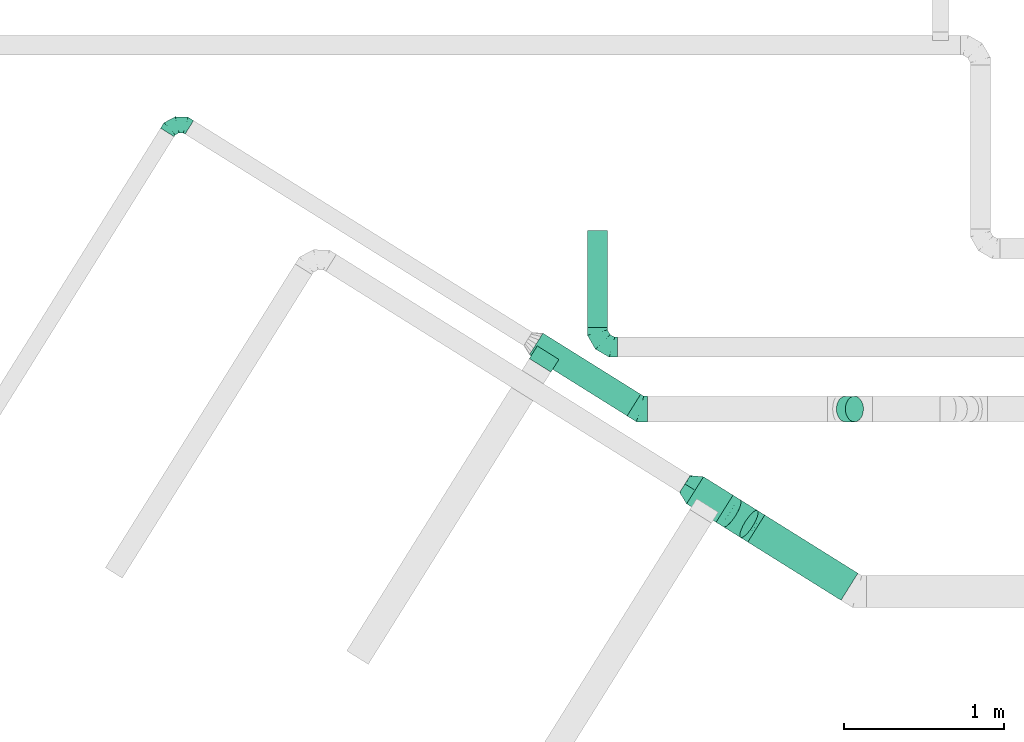
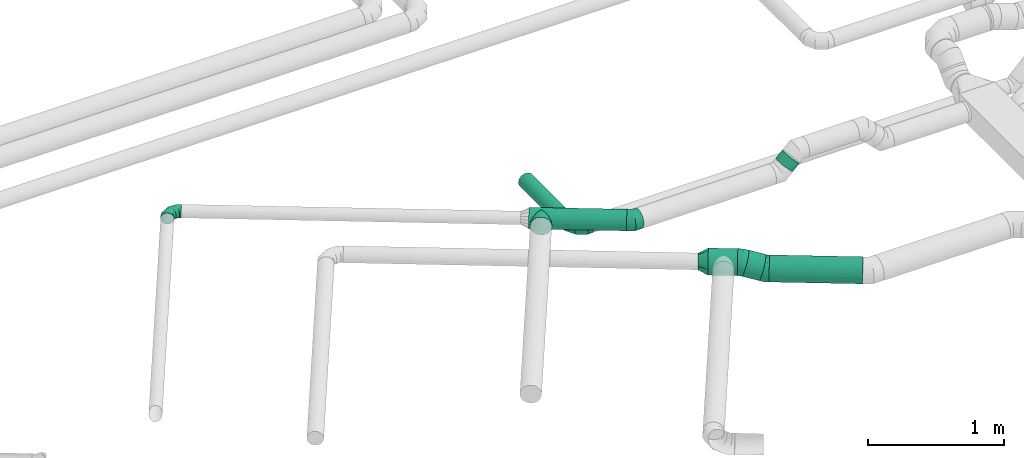
# One storey, part 9 of 60: 7 flow fittings, 6 flow segments.
"""IFC2X3 building model written with IfcOpenShell, lengths in millimetres."""

from ifc_helpers import new_model, entity, si_unit, converted_unit, derived_unit, direction, frame, origin, origin_2d_with_axis, place, context, subcontext, project, spatial, circle, extrude, faceted_brep, source, transform, mapped, material, type_object, type_shapes, element, save


model = new_model("IFC2X3")

# Units and contexts
model_context = context("Model", 3, precision=0.01, world=origin(), true_north=direction((6.12303176911189e-17, 1.0)))
body_context = subcontext(model_context, "Body", "Model", "MODEL_VIEW")
ifc_project = project(units=[si_unit("LENGTHUNIT", "METRE", prefix="MILLI"), si_unit("AREAUNIT", "SQUARE_METRE"), si_unit("VOLUMEUNIT", "CUBIC_METRE"), converted_unit("PLANEANGLEUNIT", "DEGREE", entity("IfcRatioMeasure", 0.0174532925199433), si_unit("PLANEANGLEUNIT", "RADIAN"), dimensions=[0, 0, 0, 0, 0, 0, 0]), si_unit("MASSUNIT", "GRAM", prefix="KILO"), derived_unit("MASSDENSITYUNIT", [(si_unit("MASSUNIT", "GRAM", prefix="KILO"), 1), (si_unit("LENGTHUNIT", "METRE"), -3)]), derived_unit("MOMENTOFINERTIAUNIT", [(si_unit("LENGTHUNIT", "METRE"), 4)]), si_unit("TIMEUNIT", "SECOND"), si_unit("FREQUENCYUNIT", "HERTZ"), si_unit("THERMODYNAMICTEMPERATUREUNIT", "DEGREE_CELSIUS"), derived_unit("THERMALTRANSMITTANCEUNIT", [(si_unit("MASSUNIT", "GRAM", prefix="KILO"), 1), (si_unit("THERMODYNAMICTEMPERATUREUNIT", "KELVIN"), -1), (si_unit("TIMEUNIT", "SECOND"), -3)]), derived_unit("VOLUMETRICFLOWRATEUNIT", [(si_unit("LENGTHUNIT", "METRE"), 3), (si_unit("TIMEUNIT", "SECOND"), -1)]), derived_unit("MASSFLOWRATEUNIT", [(si_unit("MASSUNIT", "GRAM", prefix="KILO"), 1), (si_unit("TIMEUNIT", "SECOND"), -1)]), derived_unit("ROTATIONALFREQUENCYUNIT", [(si_unit("TIMEUNIT", "SECOND"), -1)]), si_unit("ELECTRICCURRENTUNIT", "AMPERE"), si_unit("ELECTRICVOLTAGEUNIT", "VOLT"), si_unit("POWERUNIT", "WATT"), si_unit("FORCEUNIT", "NEWTON", prefix="KILO"), si_unit("ILLUMINANCEUNIT", "LUX"), si_unit("LUMINOUSFLUXUNIT", "LUMEN"), si_unit("LUMINOUSINTENSITYUNIT", "CANDELA"), derived_unit("USERDEFINED", [(si_unit("MASSUNIT", "GRAM", prefix="KILO"), -1), (si_unit("LENGTHUNIT", "METRE"), -2), (si_unit("TIMEUNIT", "SECOND"), 3), (si_unit("LUMINOUSFLUXUNIT", "LUMEN"), 1)]), derived_unit("LINEARVELOCITYUNIT", [(si_unit("LENGTHUNIT", "METRE"), 1), (si_unit("TIMEUNIT", "SECOND"), -1)]), si_unit("PRESSUREUNIT", "PASCAL"), derived_unit("USERDEFINED", [(si_unit("LENGTHUNIT", "METRE"), -2), (si_unit("MASSUNIT", "GRAM", prefix="KILO"), 1), (si_unit("TIMEUNIT", "SECOND"), -2)]), derived_unit("LINEARFORCEUNIT", [(si_unit("MASSUNIT", "GRAM", prefix="KILO"), 1), (si_unit("LENGTHUNIT", "METRE"), 1), (si_unit("TIMEUNIT", "SECOND"), -2), (si_unit("LENGTHUNIT", "METRE"), -1)]), derived_unit("PLANARFORCEUNIT", [(si_unit("MASSUNIT", "GRAM", prefix="KILO"), 1), (si_unit("LENGTHUNIT", "METRE"), 1), (si_unit("TIMEUNIT", "SECOND"), -2), (si_unit("LENGTHUNIT", "METRE"), -2)])], contexts=[model_context])

# Site, building, storey
site_placement = place(None, origin())
site = spatial("IfcSite", under=ifc_project, at=site_placement, CompositionType="ELEMENT")
building_placement = place(site_placement, origin())
building = spatial("IfcBuilding", under=site, at=building_placement, CompositionType="ELEMENT")
storey_placement = place(building_placement, frame((0.0, 0.0, 19800.0)))
storey = spatial("IfcBuildingStorey", under=building, at=storey_placement, CompositionType="ELEMENT", Elevation=19800.0)

# Flow segments
duct_segment_type = type_object("IfcDuctSegmentType", PredefinedType="NOTDEFINED")
flow_segment_1_placement = place(storey_placement, frame((13336.18, 9832.66, 3135.9)))
element("IfcFlowSegment", 1, at=flow_segment_1_placement, inside=storey, type_object=duct_segment_type, context=body_context, shape_type="SweptSolid", body=[
    extrude(circle(Radius=62.5, at=origin_2d_with_axis()), frame((64.1, 0.0, 64.1), z_axis=(0.0, 1.0, 0.0), x_axis=(1.0, 0.0, 0.0)), (0.0, 0.0, 1.0), 607.500000000031),
])
flow_segment_2_placement = place(storey_placement, frame((12972.44, 9275.3, 3343.4)))
element("IfcFlowSegment", 2, at=flow_segment_2_placement, inside=storey, type_object=duct_segment_type, context=body_context, shape_type="SweptSolid", body=[
    extrude(circle(Radius=80.0, at=origin_2d_with_axis()), frame((43.99, 452.23, 81.6), z_axis=(0.848048096156417, -0.52991926423322, 0.0), x_axis=(0.52991926423322, 0.848048096156417, 0.0)), (0.0, 0.0, 1.0), 722.361212402773),
])
flow_segment_3_placement = place(storey_placement, frame((14341.56, 8119.93, 3088.4)))
element("IfcFlowSegment", 3, at=flow_segment_3_placement, inside=storey, type_object=duct_segment_type, context=body_context, shape_type="SweptSolid", body=[
    extrude(circle(Radius=100.0, at=origin_2d_with_axis()), frame((54.59, 451.16, 101.6), z_axis=(0.848048096156417, -0.529919264233219, 0.0), x_axis=(0.529919264233219, 0.848048096156417, 0.0)), (0.0, 0.0, 1.0), 688.339841577361),
])
flow_segment_4_placement = place(storey_placement, frame((13957.85, 8609.03, 3138.99)))
element("IfcFlowSegment", 4, at=flow_segment_4_placement, inside=storey, type_object=duct_segment_type, context=body_context, shape_type="SweptSolid", body=[
    extrude(circle(Radius=100.0, at=origin_2d_with_axis()), frame((239.32, 86.4, 101.6), z_axis=(-0.848052743777578, 0.529911826412019, 0.0), x_axis=(0.529911826412019, 0.848052743777578, 0.0)), (0.0, 0.0, 1.0), 217.830106904879),
])
flow_segment_5_placement = place(storey_placement, frame((14184.22, 8512.64, 3099.68)))
element("IfcFlowSegment", 5, at=flow_segment_5_placement, inside=storey, type_object=duct_segment_type, context=body_context, shape_type="SweptSolid", body=[
    extrude(circle(Radius=100.0, at=origin_2d_with_axis()), frame((165.87, 87.23, 97.84), z_axis=(-0.816176385066245, 0.510025682151549, 0.271532524766454), x_axis=(-0.529935758696196, -0.848037789048983, 0.0)), (0.0, 0.0, 1.0), 130.942735235009),
])
flow_segment_6_placement = place(storey_placement, frame((14896.63, 9238.83, 3413.7)))
element("IfcFlowSegment", 6, at=flow_segment_6_placement, inside=storey, type_object=duct_segment_type, context=body_context, shape_type="SweptSolid", body=[
    extrude(circle(Radius=80.0, at=origin_2d_with_axis()), frame((58.16, 81.6, 58.16), z_axis=(0.707106781186548, 0.0, 0.707106781186548), x_axis=(0.0, -1.0, 0.0)), (0.0, 0.0, 1.0), 79.5836943965932),
])

# Flow fittings
ifc_material = material()
duct_fitting_type_1 = type_object("IfcDuctFittingType", PredefinedType="NOTDEFINED", material=ifc_material)
shared_shape_1 = source(origin(), body_context, "Body", "Brep", [
    faceted_brep([(-100.0, 0.0, -50.0), (-100.0, -12.94, -48.3), (-100.0, -25.0, -43.3), (-100.0, -35.36, -35.36), (-100.0, -43.3, -25.0), (-100.0, -48.3, -12.94), (-100.0, -50.0, 0.0), (-100.0, -48.3, 12.94), (-100.0, -43.3, 25.0), (-100.0, -35.36, 35.36), (-100.0, -25.0, 43.3), (-100.0, -12.94, 48.3), (-100.0, 0.0, 50.0), (-100.0, 12.94, 48.3), (-100.0, 25.0, 43.3), (-100.0, 35.36, 35.36), (-100.0, 43.3, 25.0), (-100.0, 48.3, 12.94), (-100.0, 50.0, 0.0), (-100.0, 48.3, -12.94), (-100.0, 43.3, -25.0), (-100.0, 35.36, -35.36), (-100.0, 25.0, -43.3), (-100.0, 12.94, -48.3), (-76.67, 12.94, 48.3), (-79.9, 25.0, 43.3), (-73.21, 0.0, 50.0), (-82.68, 35.36, 35.36), (-86.15, 48.3, 12.94), (-86.6, 50.0, 0.0), (-84.81, 43.3, 25.0), (-84.81, 43.3, -25.0), (-82.68, 35.36, -35.36), (-86.15, 48.3, -12.94), (-76.67, 12.94, -48.3), (-73.21, 0.0, -50.0), (-79.9, 25.0, -43.3), (-69.74, -12.94, -48.3), (-66.51, -25.0, -43.3), (-63.73, -35.36, -35.36), (-61.6, -43.3, -25.0), (-60.26, -48.3, -12.94), (-59.81, -50.0, 0.0), (-60.26, -48.3, 12.94), (-61.6, -43.3, 25.0), (-63.73, -35.36, 35.36), (-66.51, -25.0, 43.3), (-69.74, -12.94, 48.3), (-36.27, 36.27, 48.3), (-45.1, 45.1, 43.3), (-26.79, 26.79, 50.0), (-52.68, 52.68, 35.36), (-58.49, 58.49, 25.0), (-62.15, 62.15, 12.94), (-63.4, 63.4, 0.0), (-62.15, 62.15, -12.94), (-58.49, 58.49, -25.0), (-52.68, 52.68, -35.36), (-36.27, 36.27, -48.3), (-26.79, 26.79, -50.0), (-45.1, 45.1, -43.3), (-17.32, 17.32, -48.3), (-8.49, 8.49, -43.3), (-0.91, 0.91, -35.36), (4.9, -4.9, -25.0), (8.56, -8.56, -12.94), (9.81, -9.81, 0.0), (8.56, -8.56, 12.94), (4.9, -4.9, 25.0), (-0.91, 0.91, 35.36), (-8.49, 8.49, 43.3), (-17.32, 17.32, 48.3), (-12.94, 76.67, 48.3), (-25.0, 79.9, 43.3), (0.0, 73.21, 50.0), (-35.36, 82.68, 35.36), (-43.3, 84.81, 25.0), (-48.3, 86.15, 12.94), (-50.0, 86.6, 0.0), (-48.3, 86.15, -12.94), (-43.3, 84.81, -25.0), (-35.36, 82.68, -35.36), (-12.94, 76.67, -48.3), (0.0, 73.21, -50.0), (-25.0, 79.9, -43.3), (12.94, 69.74, -48.3), (25.0, 66.51, -43.3), (35.36, 63.73, -35.36), (43.3, 61.6, -25.0), (48.3, 60.26, -12.94), (50.0, 59.81, 0.0), (48.3, 60.26, 12.94), (43.3, 61.6, 25.0), (35.36, 63.73, 35.36), (25.0, 66.51, 43.3), (12.94, 69.74, 48.3), (-12.94, 100.0, -48.3), (-25.0, 100.0, -43.3), (-35.36, 100.0, -35.36), (-43.3, 100.0, -25.0), (-48.3, 100.0, -12.94), (-50.0, 100.0, 0.0), (-48.3, 100.0, 12.94), (-43.3, 100.0, 25.0), (-35.36, 100.0, 35.36), (-25.0, 100.0, 43.3), (-12.94, 100.0, 48.3), (0.0, 100.0, 50.0), (12.94, 100.0, 48.3), (25.0, 100.0, 43.3), (35.36, 100.0, 35.36), (43.3, 100.0, 25.0), (48.3, 100.0, 12.94), (50.0, 100.0, 0.0), (48.3, 100.0, -12.94), (43.3, 100.0, -25.0), (35.36, 100.0, -35.36), (25.0, 100.0, -43.3), (12.94, 100.0, -48.3), (0.0, 100.0, -50.0)], [[[0, 1, 2, 3, 4, 5, 6, 7, 8, 9, 10, 11, 12, 13, 14, 15, 16, 17, 18, 19, 20, 21, 22, 23]], [[24, 25, 14, 13]], [[26, 24, 13, 12]], [[14, 25, 27, 15]], [[28, 29, 18, 17]], [[30, 28, 17, 16]], [[15, 27, 30, 16]], [[20, 31, 32, 21]], [[33, 31, 20, 19]], [[18, 29, 33, 19]], [[34, 35, 0, 23]], [[36, 34, 23, 22]], [[32, 36, 22, 21]], [[2, 1, 37, 38]], [[3, 2, 38, 39]], [[0, 35, 37, 1]], [[5, 4, 40, 41]], [[6, 5, 41, 42]], [[3, 39, 40, 4]], [[6, 42, 43, 7]], [[7, 43, 44, 8]], [[8, 44, 45, 9]], [[10, 46, 47, 11]], [[11, 47, 26, 12]], [[10, 9, 45, 46]], [[48, 49, 25, 24]], [[50, 48, 24, 26]], [[27, 25, 49, 51]], [[52, 53, 28, 30]], [[51, 52, 30, 27]], [[29, 28, 53, 54]], [[55, 56, 31, 33]], [[54, 55, 33, 29]], [[57, 32, 31, 56]], [[58, 59, 35, 34]], [[60, 58, 34, 36]], [[57, 60, 36, 32]], [[37, 35, 59, 61]], [[38, 37, 61, 62]], [[39, 38, 62, 63]], [[41, 40, 64, 65]], [[42, 41, 65, 66]], [[63, 64, 40, 39]], [[43, 42, 66, 67]], [[44, 43, 67, 68]], [[68, 69, 45, 44]], [[46, 45, 69, 70]], [[47, 46, 70, 71]], [[26, 47, 71, 50]], [[72, 73, 49, 48]], [[74, 72, 48, 50]], [[51, 49, 73, 75]], [[76, 77, 53, 52]], [[75, 76, 52, 51]], [[54, 53, 77, 78]], [[79, 80, 56, 55]], [[78, 79, 55, 54]], [[81, 57, 56, 80]], [[82, 83, 59, 58]], [[84, 82, 58, 60]], [[81, 84, 60, 57]], [[61, 59, 83, 85]], [[62, 61, 85, 86]], [[63, 62, 86, 87]], [[65, 64, 88, 89]], [[66, 65, 89, 90]], [[87, 88, 64, 63]], [[67, 66, 90, 91]], [[68, 67, 91, 92]], [[92, 93, 69, 68]], [[70, 69, 93, 94]], [[71, 70, 94, 95]], [[50, 71, 95, 74]], [[96, 97, 98, 99, 100, 101, 102, 103, 104, 105, 106, 107, 108, 109, 110, 111, 112, 113, 114, 115, 116, 117, 118, 119]], [[72, 74, 107, 106]], [[73, 72, 106, 105]], [[75, 73, 105, 104]], [[77, 76, 103, 102]], [[78, 77, 102, 101]], [[75, 104, 103, 76]], [[78, 101, 100, 79]], [[79, 100, 99, 80]], [[80, 99, 98, 81]], [[96, 119, 83, 82]], [[97, 96, 82, 84]], [[84, 81, 98, 97]], [[83, 119, 118, 85]], [[85, 118, 117, 86]], [[86, 117, 116, 87]], [[88, 115, 114, 89]], [[89, 114, 113, 90]], [[87, 116, 115, 88]], [[91, 90, 113, 112]], [[92, 91, 112, 111]], [[93, 92, 111, 110]], [[95, 94, 109, 108]], [[74, 95, 108, 107]], [[110, 109, 94, 93]]]),
])
type_shapes(duct_fitting_type_1, [shared_shape_1])
flow_fitting_1_placement = place(storey_placement, frame((10758.13, 11138.67, 3425.0), z_axis=(0.0, 0.0, 1.0), x_axis=(-0.848048096156419, 0.529919264233217, 0.0)))
element("IfcFlowFitting", 7, at=flow_fitting_1_placement, inside=storey, type_object=duct_fitting_type_1, material=ifc_material, context=body_context, shape_type="MappedRepresentation", body=[
    mapped(shared_shape_1, transform((0.0, 0.0, 0.0), scale=1.0)),
])
duct_fitting_type_2 = type_object("IfcDuctFittingType", PredefinedType="NOTDEFINED", material=ifc_material)
shared_shape_2 = source(origin(), body_context, "Body", "Brep", [
    faceted_brep([(-125.0, 0.0, -62.5), (-125.0, -16.18, -60.37), (-125.0, -31.25, -54.13), (-125.0, -44.19, -44.19), (-125.0, -54.13, -31.25), (-125.0, -60.37, -16.18), (-125.0, -62.5, 0.0), (-125.0, -60.37, 16.18), (-125.0, -54.13, 31.25), (-125.0, -44.19, 44.19), (-125.0, -31.25, 54.13), (-125.0, -16.18, 60.37), (-125.0, 0.0, 62.5), (-125.0, 16.18, 60.37), (-125.0, 31.25, 54.13), (-125.0, 44.19, 44.19), (-125.0, 54.13, 31.25), (-125.0, 60.37, 16.18), (-125.0, 62.5, 0.0), (-125.0, 60.37, -16.18), (-125.0, 54.13, -31.25), (-125.0, 44.19, -44.19), (-125.0, 31.25, -54.13), (-125.0, 16.18, -60.37), (-95.84, 16.18, 60.37), (-99.88, 31.25, 54.13), (-91.51, 0.0, 62.5), (-103.35, 44.19, 44.19), (-107.68, 60.37, 16.18), (-108.25, 62.5, 0.0), (-106.01, 54.13, 31.25), (-106.01, 54.13, -31.25), (-103.35, 44.19, -44.19), (-107.68, 60.37, -16.18), (-95.84, 16.18, -60.37), (-91.51, 0.0, -62.5), (-99.88, 31.25, -54.13), (-87.17, -16.18, -60.37), (-83.13, -31.25, -54.13), (-79.66, -44.19, -44.19), (-77.0, -54.13, -31.25), (-75.33, -60.37, -16.18), (-74.76, -62.5, 0.0), (-75.33, -60.37, 16.18), (-77.0, -54.13, 31.25), (-79.66, -44.19, 44.19), (-83.13, -31.25, 54.13), (-87.17, -16.18, 60.37), (-45.34, 45.34, 60.37), (-56.37, 56.37, 54.13), (-33.49, 33.49, 62.5), (-65.85, 65.85, 44.19), (-73.12, 73.12, 31.25), (-77.69, 77.69, 16.18), (-79.25, 79.25, 0.0), (-77.69, 77.69, -16.18), (-73.12, 73.12, -31.25), (-65.85, 65.85, -44.19), (-45.34, 45.34, -60.37), (-33.49, 33.49, -62.5), (-56.37, 56.37, -54.13), (-21.65, 21.65, -60.37), (-10.62, 10.62, -54.13), (-1.14, 1.14, -44.19), (6.13, -6.13, -31.25), (10.7, -10.7, -16.18), (12.26, -12.26, 0.0), (10.7, -10.7, 16.18), (6.13, -6.13, 31.25), (-1.14, 1.14, 44.19), (-10.62, 10.62, 54.13), (-21.65, 21.65, 60.37), (-16.18, 95.84, 60.37), (-31.25, 99.88, 54.13), (0.0, 91.51, 62.5), (-44.19, 103.35, 44.19), (-54.13, 106.01, 31.25), (-60.37, 107.68, 16.18), (-62.5, 108.25, 0.0), (-60.37, 107.68, -16.18), (-54.13, 106.01, -31.25), (-44.19, 103.35, -44.19), (-16.18, 95.84, -60.37), (0.0, 91.51, -62.5), (-31.25, 99.88, -54.13), (16.18, 87.17, -60.37), (31.25, 83.13, -54.13), (44.19, 79.66, -44.19), (54.13, 77.0, -31.25), (60.37, 75.33, -16.18), (62.5, 74.76, 0.0), (60.37, 75.33, 16.18), (54.13, 77.0, 31.25), (44.19, 79.66, 44.19), (31.25, 83.13, 54.13), (16.18, 87.17, 60.37), (-16.18, 125.0, -60.37), (-31.25, 125.0, -54.13), (-44.19, 125.0, -44.19), (-54.13, 125.0, -31.25), (-60.37, 125.0, -16.18), (-62.5, 125.0, 0.0), (-60.37, 125.0, 16.18), (-54.13, 125.0, 31.25), (-44.19, 125.0, 44.19), (-31.25, 125.0, 54.13), (-16.18, 125.0, 60.37), (0.0, 125.0, 62.5), (16.18, 125.0, 60.37), (31.25, 125.0, 54.13), (44.19, 125.0, 44.19), (54.13, 125.0, 31.25), (60.37, 125.0, 16.18), (62.5, 125.0, 0.0), (60.37, 125.0, -16.18), (54.13, 125.0, -31.25), (44.19, 125.0, -44.19), (31.25, 125.0, -54.13), (16.18, 125.0, -60.37), (0.0, 125.0, -62.5)], [[[0, 1, 2, 3, 4, 5, 6, 7, 8, 9, 10, 11, 12, 13, 14, 15, 16, 17, 18, 19, 20, 21, 22, 23]], [[24, 25, 14, 13]], [[26, 24, 13, 12]], [[14, 25, 27, 15]], [[28, 29, 18, 17]], [[30, 28, 17, 16]], [[15, 27, 30, 16]], [[20, 31, 32, 21]], [[33, 31, 20, 19]], [[18, 29, 33, 19]], [[34, 35, 0, 23]], [[36, 34, 23, 22]], [[21, 32, 36, 22]], [[1, 0, 35, 37]], [[2, 1, 37, 38]], [[38, 39, 3, 2]], [[5, 4, 40, 41]], [[6, 5, 41, 42]], [[39, 40, 4, 3]], [[6, 42, 43, 7]], [[7, 43, 44, 8]], [[45, 9, 8, 44]], [[9, 45, 46, 10]], [[10, 46, 47, 11]], [[26, 12, 11, 47]], [[48, 49, 25, 24]], [[50, 48, 24, 26]], [[27, 25, 49, 51]], [[52, 53, 28, 30]], [[51, 52, 30, 27]], [[29, 28, 53, 54]], [[55, 56, 31, 33]], [[54, 55, 33, 29]], [[57, 32, 31, 56]], [[58, 59, 35, 34]], [[60, 58, 34, 36]], [[57, 60, 36, 32]], [[37, 35, 59, 61]], [[38, 37, 61, 62]], [[39, 38, 62, 63]], [[41, 40, 64, 65]], [[42, 41, 65, 66]], [[63, 64, 40, 39]], [[43, 42, 66, 67]], [[44, 43, 67, 68]], [[68, 69, 45, 44]], [[46, 45, 69, 70]], [[47, 46, 70, 71]], [[26, 47, 71, 50]], [[72, 73, 49, 48]], [[74, 72, 48, 50]], [[51, 49, 73, 75]], [[76, 77, 53, 52]], [[75, 76, 52, 51]], [[54, 53, 77, 78]], [[79, 80, 56, 55]], [[78, 79, 55, 54]], [[81, 57, 56, 80]], [[82, 83, 59, 58]], [[84, 82, 58, 60]], [[81, 84, 60, 57]], [[61, 59, 83, 85]], [[62, 61, 85, 86]], [[63, 62, 86, 87]], [[65, 64, 88, 89]], [[66, 65, 89, 90]], [[87, 88, 64, 63]], [[67, 66, 90, 91]], [[68, 67, 91, 92]], [[92, 93, 69, 68]], [[70, 69, 93, 94]], [[71, 70, 94, 95]], [[50, 71, 95, 74]], [[96, 97, 98, 99, 100, 101, 102, 103, 104, 105, 106, 107, 108, 109, 110, 111, 112, 113, 114, 115, 116, 117, 118, 119]], [[72, 74, 107, 106]], [[73, 72, 106, 105]], [[75, 73, 105, 104]], [[77, 76, 103, 102]], [[78, 77, 102, 101]], [[75, 104, 103, 76]], [[78, 101, 100, 79]], [[79, 100, 99, 80]], [[80, 99, 98, 81]], [[96, 119, 83, 82]], [[97, 96, 82, 84]], [[84, 81, 98, 97]], [[83, 119, 118, 85]], [[85, 118, 117, 86]], [[116, 87, 86, 117]], [[88, 115, 114, 89]], [[89, 114, 113, 90]], [[115, 88, 87, 116]], [[91, 90, 113, 112]], [[92, 91, 112, 111]], [[111, 110, 93, 92]], [[95, 94, 109, 108]], [[74, 95, 108, 107]], [[110, 109, 94, 93]]]),
])
type_shapes(duct_fitting_type_2, [shared_shape_2])
flow_fitting_2_placement = place(storey_placement, frame((13400.27, 9707.66, 3200.0), z_axis=(0.0, 0.0, 1.0), x_axis=(0.0, -1.0, 0.0)))
element("IfcFlowFitting", 8, at=flow_fitting_2_placement, inside=storey, type_object=duct_fitting_type_2, material=ifc_material, context=body_context, shape_type="MappedRepresentation", body=[
    mapped(shared_shape_2, transform((0.0, 0.0, 0.0), scale=1.0)),
])
duct_fitting_type_3 = type_object("IfcDuctFittingType", PredefinedType="NOTDEFINED", material=ifc_material)
shared_shape_3 = source(origin(), body_context, "Body", "Brep", [
    faceted_brep([(75.0, -57.74, 23.92), (75.0, -60.12, 11.96), (75.0, -62.5, 0.0), (75.0, -60.12, -11.96), (75.0, -57.74, -23.92), (75.0, -50.97, -34.06), (75.0, -44.19, -44.19), (75.0, -34.06, -50.97), (75.0, -23.92, -57.74), (75.0, -11.96, -60.12), (75.0, 0.0, -62.5), (75.0, 11.96, -60.12), (75.0, 23.92, -57.74), (75.0, 34.06, -50.97), (75.0, 44.19, -44.19), (75.0, 50.97, -34.06), (75.0, 57.74, -23.92), (75.0, 60.12, -11.96), (75.0, 62.5, 0.0), (75.0, 60.12, 11.96), (75.0, 57.74, 23.92), (75.0, 50.97, 34.06), (75.0, 44.19, 44.19), (75.0, 34.06, 50.97), (75.0, 23.92, 57.74), (75.0, 11.96, 60.12), (75.0, 0.0, 62.5), (75.0, -11.96, 60.12), (75.0, -23.92, 57.74), (75.0, -34.06, 50.97), (75.0, -44.19, 44.19), (75.0, -50.97, 34.06), (0.0, -100.0, 0.0), (0.0, -95.11, 30.9), (0.0, -80.9, 58.78), (0.0, -58.78, 80.9), (0.0, -30.9, 95.11), (0.0, 0.0, 100.0), (0.0, 30.9, 95.11), (0.0, 58.78, 80.9), (0.0, 80.9, 58.78), (0.0, 95.11, 30.9), (0.0, 100.0, 0.0), (0.0, 95.11, -30.9), (0.0, 80.9, -58.78), (0.0, 58.78, -80.9), (0.0, 30.9, -95.11), (0.0, 0.0, -100.0), (0.0, -30.9, -95.11), (0.0, -58.78, -80.9), (0.0, -80.9, -58.78), (0.0, -95.11, -30.9)], [[[0, 1, 2, 3, 4, 5, 6, 7, 8, 9, 10, 11, 12, 13, 14, 15, 16, 17, 18, 19, 20, 21, 22, 23, 24, 25, 26, 27, 28, 29, 30, 31]], [[32, 33, 34, 35, 36, 37, 38, 39, 40, 41, 42, 43, 44, 45, 46, 47, 48, 49, 50, 51]], [[37, 25, 38]], [[41, 20, 19]], [[24, 39, 38]], [[40, 22, 21, 20]], [[23, 22, 39, 24]], [[18, 42, 19]], [[25, 24, 38]], [[40, 20, 41]], [[19, 42, 41]], [[25, 37, 26]], [[22, 40, 39]], [[32, 1, 33]], [[36, 28, 27]], [[0, 34, 33]], [[35, 30, 29, 28]], [[31, 30, 34, 0]], [[26, 37, 27]], [[1, 0, 33]], [[35, 28, 36]], [[27, 37, 36]], [[1, 32, 2]], [[30, 35, 34]], [[47, 9, 48]], [[51, 4, 3]], [[8, 49, 48]], [[50, 6, 5, 4]], [[7, 6, 49, 8]], [[2, 32, 3]], [[9, 8, 48]], [[50, 4, 51]], [[3, 32, 51]], [[9, 47, 10]], [[6, 50, 49]], [[42, 17, 43]], [[46, 12, 11]], [[16, 44, 43]], [[45, 14, 13, 12]], [[15, 14, 44, 16]], [[10, 47, 11]], [[17, 16, 43]], [[45, 12, 46]], [[11, 47, 46]], [[17, 42, 18]], [[14, 45, 44]]]),
])
type_shapes(duct_fitting_type_3, [shared_shape_3])
flow_fitting_3_placement = place(storey_placement, frame((14012.43, 8810.86, 3240.0), z_axis=(0.0, 0.0, 1.0), x_axis=(-0.848052743777577, 0.52991182641202, 0.0)))
element("IfcFlowFitting", 9, at=flow_fitting_3_placement, inside=storey, type_object=duct_fitting_type_3, material=ifc_material, context=body_context, shape_type="MappedRepresentation", body=[
    mapped(shared_shape_3, transform((0.0, 0.0, 0.0), scale=1.0)),
])
duct_fitting_type_4 = type_object("IfcDuctFittingType", PredefinedType="NOTDEFINED", material=ifc_material)
shared_shape_4 = source(origin(), body_context, "Body", "Brep", [
    faceted_brep([(-45.88, 0.0, -80.0), (-45.88, -20.71, -77.27), (-45.88, -40.0, -69.28), (-45.88, -56.57, -56.57), (-45.88, -69.28, -40.0), (-45.88, -77.27, -20.71), (-45.88, -80.0, 0.0), (-45.88, -77.27, 20.71), (-45.88, -69.28, 40.0), (-45.88, -56.57, 56.57), (-45.88, -40.0, 69.28), (-45.88, -20.71, 77.27), (-45.88, 0.0, 80.0), (-45.88, 20.71, 77.27), (-45.88, 40.0, 69.28), (-45.88, 56.57, 56.57), (-45.88, 69.28, 40.0), (-45.88, 77.27, 20.71), (-45.88, 80.0, 0.0), (-45.88, 77.27, -20.71), (-45.88, 69.28, -40.0), (-45.88, 56.57, -56.57), (-45.88, 40.0, -69.28), (-45.88, 20.71, -77.27), (-5.94, 20.71, 77.27), (-11.47, 40.0, 69.28), (0.0, 0.0, 80.0), (-16.22, 56.57, 56.57), (-22.16, 77.27, 20.71), (-22.94, 80.0, 0.0), (-19.87, 69.28, 40.0), (-19.87, 69.28, -40.0), (-16.22, 56.57, -56.57), (-22.16, 77.27, -20.71), (-5.94, 20.71, -77.27), (0.0, 0.0, -80.0), (-11.47, 40.0, -69.28), (5.94, -20.71, -77.27), (11.47, -40.0, -69.28), (16.22, -56.57, -56.57), (19.87, -69.28, -40.0), (22.16, -77.27, -20.71), (22.94, -80.0, 0.0), (22.16, -77.27, 20.71), (19.87, -69.28, 40.0), (16.22, -56.57, 56.57), (11.47, -40.0, 69.28), (5.94, -20.71, 77.27), (38.91, 24.31, 80.0), (27.94, 41.87, 77.27), (17.71, 58.23, 69.28), (8.93, 72.29, 56.57), (2.19, 83.07, 40.0), (-2.04, 89.84, 20.71), (-3.49, 92.16, 0.0), (-2.04, 89.84, -20.71), (2.19, 83.07, -40.0), (8.93, 72.29, -56.57), (17.71, 58.23, -69.28), (27.94, 41.87, -77.27), (38.91, 24.31, -80.0), (49.88, 6.75, -77.27), (60.1, -9.61, -69.28), (68.88, -23.66, -56.57), (75.62, -34.44, -40.0), (79.86, -41.22, -20.71), (81.3, -43.53, 0.0), (79.86, -41.22, 20.71), (75.62, -34.44, 40.0), (68.88, -23.66, 56.57), (60.1, -9.61, 69.28), (49.88, 6.75, 77.27)], [[[0, 1, 2, 3, 4, 5, 6, 7, 8, 9, 10, 11, 12, 13, 14, 15, 16, 17, 18, 19, 20, 21, 22, 23]], [[24, 25, 14, 13]], [[26, 24, 13, 12]], [[14, 25, 27, 15]], [[28, 29, 18, 17]], [[30, 28, 17, 16]], [[15, 27, 30, 16]], [[20, 31, 32, 21]], [[33, 31, 20, 19]], [[18, 29, 33, 19]], [[34, 35, 0, 23]], [[36, 34, 23, 22]], [[32, 36, 22, 21]], [[1, 0, 35, 37]], [[2, 1, 37, 38]], [[38, 39, 3, 2]], [[5, 4, 40, 41]], [[6, 5, 41, 42]], [[39, 40, 4, 3]], [[6, 42, 43, 7]], [[7, 43, 44, 8]], [[8, 44, 45, 9]], [[9, 45, 46, 10]], [[10, 46, 47, 11]], [[26, 12, 11, 47]], [[24, 26, 48, 49]], [[25, 24, 49, 50]], [[27, 25, 50, 51]], [[28, 30, 52, 53]], [[29, 28, 53, 54]], [[27, 51, 52, 30]], [[29, 54, 55, 33]], [[33, 55, 56, 31]], [[31, 56, 57, 32]], [[36, 58, 59, 34]], [[34, 59, 60, 35]], [[36, 32, 57, 58]], [[61, 62, 38, 37]], [[60, 61, 37, 35]], [[63, 39, 38, 62]], [[40, 64, 65, 41]], [[41, 65, 66, 42]], [[64, 40, 39, 63]], [[43, 42, 66, 67]], [[44, 43, 67, 68]], [[68, 69, 45, 44]], [[47, 46, 70, 71]], [[26, 47, 71, 48]], [[69, 70, 46, 45]], [[59, 58, 57, 56, 55, 54, 53, 52, 51, 50, 49, 48, 71, 70, 69, 68, 67, 66, 65, 64, 63, 62, 61, 60]]]),
])
type_shapes(duct_fitting_type_4, [shared_shape_4])
flow_fitting_4_placement = place(storey_placement, frame((13667.93, 9320.42, 3425.0), z_axis=(0.0, 0.0, 1.0), x_axis=(0.848048096156425, -0.529919264233207, 0.0)))
element("IfcFlowFitting", 10, at=flow_fitting_4_placement, inside=storey, type_object=duct_fitting_type_4, material=ifc_material, context=body_context, shape_type="MappedRepresentation", body=[
    mapped(shared_shape_4, transform((0.0, 0.0, 0.0), scale=1.0)),
])
duct_fitting_type_5 = type_object("IfcDuctFittingType", PredefinedType="NOTDEFINED", material=ifc_material)
shared_shape_5 = source(origin(), body_context, "Body", "Brep", [
    faceted_brep([(20.0, 0.0, -80.0), (20.0, 20.71, -77.27), (20.0, 40.0, -69.28), (20.0, 56.57, -56.57), (20.0, 69.28, -40.0), (20.0, 77.27, -20.71), (20.0, 80.0, 0.0), (20.0, 77.27, 20.71), (20.0, 69.28, 40.0), (20.0, 56.57, 56.57), (20.0, 40.0, 69.28), (20.0, 20.71, 77.27), (20.0, 0.0, 80.0), (20.0, -20.71, 77.27), (20.0, -40.0, 69.28), (20.0, -56.57, 56.57), (20.0, -69.28, 40.0), (20.0, -77.27, 20.71), (20.0, -80.0, 0.0), (20.0, -77.27, -20.71), (20.0, -69.28, -40.0), (20.0, -56.57, -56.57), (20.0, -40.0, -69.28), (20.0, -20.71, -77.27), (0.0, 0.0, 80.0), (-73.9, 0.0, 80.0), (-73.9, -20.71, 77.27), (0.0, -20.71, 77.27), (-73.9, -40.0, 69.28), (0.0, -40.0, 69.28), (0.0, -56.57, 56.57), (-73.9, -56.57, 56.57), (0.0, -69.28, 40.0), (-73.9, -69.28, 40.0), (-73.9, -77.27, 20.71), (0.0, -77.27, 20.71), (-73.9, -80.0, 0.0), (0.0, -80.0, 0.0), (-73.9, -77.27, -20.71), (0.0, -77.27, -20.71), (-73.9, -69.28, -40.0), (0.0, -69.28, -40.0), (0.0, -56.57, -56.57), (-73.9, -56.57, -56.57), (0.0, -40.0, -69.28), (-73.9, -40.0, -69.28), (-73.9, -20.71, -77.27), (0.0, -20.71, -77.27), (-73.9, 0.0, -80.0), (0.0, 0.0, -80.0), (-73.9, 20.71, -77.27), (0.0, 20.71, -77.27), (-73.9, 40.0, -69.28), (0.0, 40.0, -69.28), (0.0, 56.57, -56.57), (-73.9, 56.57, -56.57), (0.0, 69.28, -40.0), (-73.9, 69.28, -40.0), (-73.9, 77.27, -20.71), (0.0, 77.27, -20.71), (-73.9, 80.0, 0.0), (0.0, 80.0, 0.0), (-73.9, 77.27, 20.71), (0.0, 77.27, 20.71), (-73.9, 69.28, 40.0), (0.0, 69.28, 40.0), (0.0, 56.57, 56.57), (-73.9, 56.57, 56.57), (0.0, 40.0, 69.28), (-73.9, 40.0, 69.28), (-73.9, 20.71, 77.27), (0.0, 20.71, 77.27)], [[[0, 1, 2, 3, 4, 5, 6, 7, 8, 9, 10, 11, 12, 13, 14, 15, 16, 17, 18, 19, 20, 21, 22, 23]], [[13, 12, 24, 25, 26, 27]], [[14, 13, 27, 26, 28, 29]], [[30, 15, 14, 29, 28, 31]], [[17, 16, 32, 33, 34, 35]], [[18, 17, 35, 34, 36, 37]], [[32, 16, 15, 30, 31, 33]], [[19, 18, 37, 36, 38, 39]], [[20, 19, 39, 38, 40, 41]], [[42, 21, 20, 41, 40, 43]], [[23, 22, 44, 45, 46, 47]], [[0, 23, 47, 46, 48, 49]], [[44, 22, 21, 42, 43, 45]], [[1, 0, 49, 48, 50, 51]], [[2, 1, 51, 50, 52, 53]], [[54, 3, 2, 53, 52, 55]], [[5, 4, 56, 57, 58, 59]], [[6, 5, 59, 58, 60, 61]], [[56, 4, 3, 54, 55, 57]], [[7, 6, 61, 60, 62, 63]], [[8, 7, 63, 62, 64, 65]], [[66, 9, 8, 65, 64, 67]], [[11, 10, 68, 69, 70, 71]], [[12, 11, 71, 70, 25, 24]], [[68, 10, 9, 66, 67, 69]], [[46, 45, 43, 40, 38, 36, 34, 33, 31, 28, 26, 25, 70, 69, 67, 64, 62, 60, 58, 57, 55, 52, 50, 48]]]),
])
type_shapes(duct_fitting_type_5, [shared_shape_5])
flow_fitting_5_placement = place(storey_placement, frame((13052.11, 9610.9, 3425.0), z_axis=(0.0, 0.0, -1.0), x_axis=(-0.529911353855661, -0.848053039057617, 0.0)))
element("IfcFlowFitting", 11, at=flow_fitting_5_placement, inside=storey, type_object=duct_fitting_type_5, material=ifc_material, context=body_context, shape_type="MappedRepresentation", body=[
    mapped(shared_shape_5, transform((0.0, 0.0, 0.0), scale=1.0)),
])
duct_fitting_type_6 = type_object("IfcDuctFittingType", PredefinedType="NOTDEFINED", material=ifc_material)
shared_shape_6 = source(origin(), body_context, "Body", "Brep", [
    faceted_brep([(-27.67, 0.0, -100.0), (-27.67, -25.88, -96.59), (-27.67, -50.0, -86.6), (-27.67, -70.71, -70.71), (-27.67, -86.6, -50.0), (-27.67, -96.59, -25.88), (-27.67, -100.0, 0.0), (-27.67, -96.59, 25.88), (-27.67, -86.6, 50.0), (-27.67, -70.71, 70.71), (-27.67, -50.0, 86.6), (-27.67, -25.88, 96.59), (-27.67, 0.0, 100.0), (-27.67, 25.88, 96.59), (-27.67, 50.0, 86.6), (-27.67, 70.71, 70.71), (-27.67, 86.6, 50.0), (-27.67, 96.59, 25.88), (-27.67, 100.0, 0.0), (-27.67, 96.59, -25.88), (-27.67, 86.6, -50.0), (-27.67, 70.71, -70.71), (-27.67, 50.0, -86.6), (-27.67, 25.88, -96.59), (-3.58, 25.88, 96.59), (-6.92, 50.0, 86.6), (0.0, 0.0, 100.0), (-9.78, 70.71, 70.71), (-13.37, 96.59, 25.88), (-13.84, 100.0, 0.0), (-11.98, 86.6, 50.0), (-11.98, 86.6, -50.0), (-9.78, 70.71, -70.71), (-13.37, 96.59, -25.88), (-3.58, 25.88, -96.59), (0.0, 0.0, -100.0), (-6.92, 50.0, -86.6), (3.58, -25.88, -96.59), (6.92, -50.0, -86.6), (9.78, -70.71, -70.71), (11.98, -86.6, -50.0), (13.37, -96.59, -25.88), (13.84, -100.0, 0.0), (13.37, -96.59, 25.88), (11.98, -86.6, 50.0), (9.78, -70.71, 70.71), (6.92, -50.0, 86.6), (3.58, -25.88, 96.59), (26.63, 7.51, 100.0), (19.61, 32.42, 96.59), (13.06, 55.64, 86.6), (7.43, 75.57, 70.71), (3.12, 90.86, 50.0), (0.41, 100.48, 25.88), (-0.52, 103.76, 0.0), (0.41, 100.48, -25.88), (3.12, 90.86, -50.0), (7.43, 75.57, -70.71), (13.06, 55.64, -86.6), (19.61, 32.42, -96.59), (26.63, 7.51, -100.0), (33.66, -17.4, -96.59), (40.21, -40.61, -86.6), (45.83, -60.54, -70.71), (50.15, -75.83, -50.0), (52.86, -85.45, -25.88), (53.79, -88.73, 0.0), (52.86, -85.45, 25.88), (50.15, -75.83, 50.0), (45.83, -60.54, 70.71), (40.21, -40.61, 86.6), (33.66, -17.4, 96.59)], [[[0, 1, 2, 3, 4, 5, 6, 7, 8, 9, 10, 11, 12, 13, 14, 15, 16, 17, 18, 19, 20, 21, 22, 23]], [[24, 25, 14, 13]], [[26, 24, 13, 12]], [[14, 25, 27, 15]], [[28, 29, 18, 17]], [[30, 28, 17, 16]], [[15, 27, 30, 16]], [[20, 31, 32, 21]], [[33, 31, 20, 19]], [[18, 29, 33, 19]], [[34, 35, 0, 23]], [[36, 34, 23, 22]], [[32, 36, 22, 21]], [[2, 1, 37, 38]], [[3, 2, 38, 39]], [[0, 35, 37, 1]], [[5, 4, 40, 41]], [[6, 5, 41, 42]], [[39, 40, 4, 3]], [[6, 42, 43, 7]], [[7, 43, 44, 8]], [[8, 44, 45, 9]], [[10, 46, 47, 11]], [[11, 47, 26, 12]], [[9, 45, 46, 10]], [[24, 26, 48, 49]], [[25, 24, 49, 50]], [[27, 25, 50, 51]], [[28, 30, 52, 53]], [[29, 28, 53, 54]], [[27, 51, 52, 30]], [[29, 54, 55, 33]], [[33, 55, 56, 31]], [[31, 56, 57, 32]], [[36, 58, 59, 34]], [[34, 59, 60, 35]], [[36, 32, 57, 58]], [[35, 60, 61, 37]], [[37, 61, 62, 38]], [[38, 62, 63, 39]], [[40, 64, 65, 41]], [[41, 65, 66, 42]], [[39, 63, 64, 40]], [[43, 42, 66, 67]], [[44, 43, 67, 68]], [[45, 44, 68, 69]], [[47, 46, 70, 71]], [[26, 47, 71, 48]], [[69, 70, 46, 45]], [[59, 58, 57, 56, 55, 54, 53, 52, 51, 50, 49, 48, 71, 70, 69, 68, 67, 66, 65, 64, 63, 62, 61, 60]]]),
])
type_shapes(duct_fitting_type_6, [shared_shape_6])
for number, where, z_axis, x_axis in (
    (12, (14220.63, 8680.77, 3240.58), (0.529911823761088, 0.848052739535128, -0.000100025809922871), (0.848052743777581, -0.529911826412015, 0.0)),
    (13, (14372.68, 8585.76, 3190.0), (0.529911351099018, 0.84805303464597, -0.000102000857753828), (-0.848053039057616, 0.529911353855663, 0.0)),
):
    element("IfcFlowFitting", number, at=place(storey_placement, frame(where, z_axis=z_axis, x_axis=x_axis)), inside=storey, type_object=duct_fitting_type_6, material=ifc_material, context=body_context, shape_type="MappedRepresentation", body=[
        mapped(shared_shape_6, transform((0.0, 0.0, 0.0), scale=1.0)),
    ])

save(model, "model.ifc")
